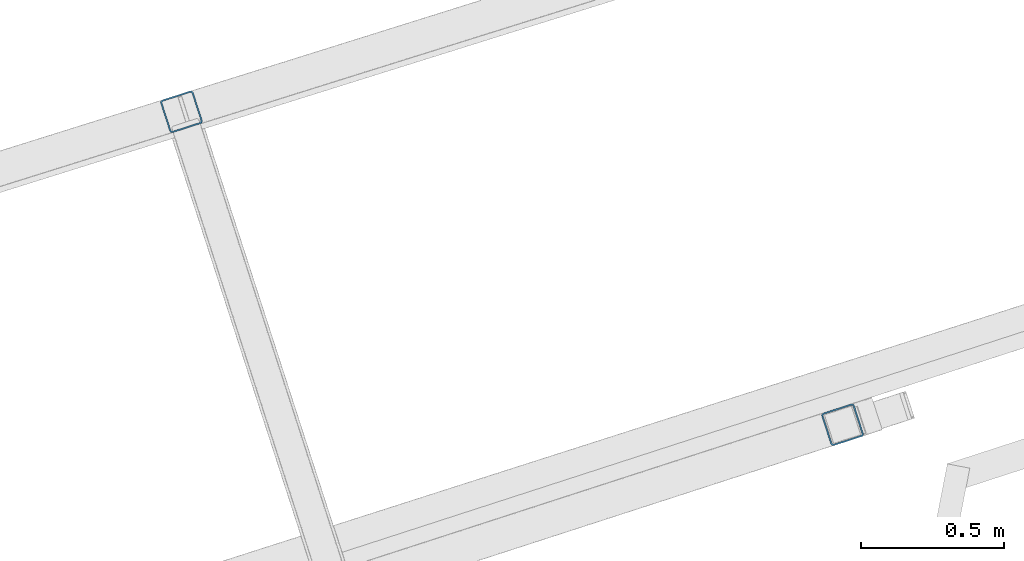
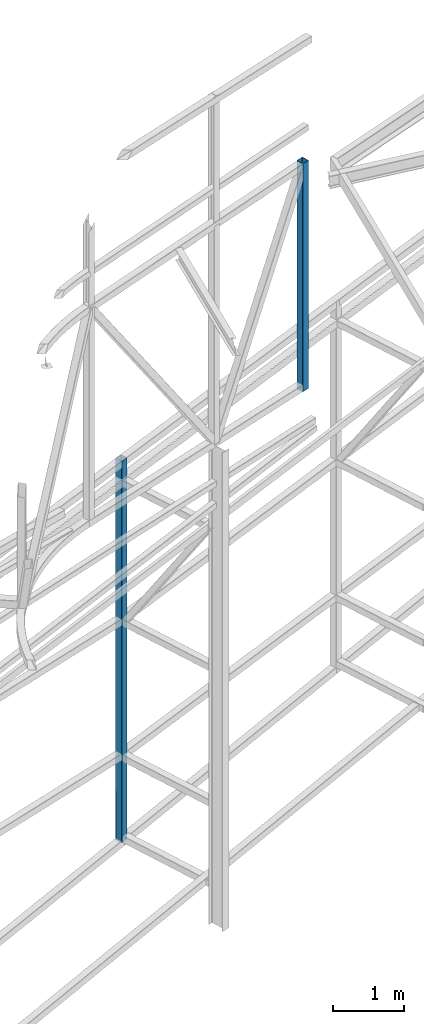
# One storey, part 84 of 215: 2 beams, 2 elements without a shape of their own.
"""IFC2X3 building model written with IfcOpenShell, lengths in millimetres."""

from ifc_helpers import new_model, si_unit, frame, origin_with_axes, origin_2d_with_axis, place, context, subcontext, project, spatial, hollow_rectangle, extrude, clip, halfspace, material, type_object, element, aggregate, save


model = new_model("IFC2X3")

# Units and contexts
model_context = context("Model", 3, precision=1e-05, world=origin_with_axes())
body_context = subcontext(model_context, "Body", "Model", "MODEL_VIEW")
ifc_project = project(units=[si_unit("LENGTHUNIT", "METRE", prefix="MILLI"), si_unit("AREAUNIT", "SQUARE_METRE"), si_unit("VOLUMEUNIT", "CUBIC_METRE"), si_unit("MASSUNIT", "GRAM", prefix="KILO"), si_unit("TIMEUNIT", "SECOND"), si_unit("PLANEANGLEUNIT", "RADIAN"), si_unit("SOLIDANGLEUNIT", "STERADIAN"), si_unit("THERMODYNAMICTEMPERATUREUNIT", "DEGREE_CELSIUS"), si_unit("LUMINOUSINTENSITYUNIT", "LUMEN")], contexts=[model_context])

# Site, building, storey
site_placement = place(None, origin_with_axes())
site = spatial("IfcSite", under=ifc_project, at=site_placement, CompositionType="ELEMENT")
building_placement = place(site_placement, origin_with_axes())
building = spatial("IfcBuilding", under=site, at=building_placement, Name="Undefined", CompositionType="ELEMENT")
storey_placement = place(building_placement, origin_with_axes())
storey = spatial("IfcBuildingStorey", under=building, at=storey_placement, Name="Undefined", CompositionType="ELEMENT", Elevation=0.0)

# Assembly, beam
assembly_1_placement = place(storey_placement, origin_with_axes())
assembly_1 = element("IfcElementAssembly", 1, at=assembly_1_placement, inside=storey, Name="Steel Assembly", AssemblyPlace="NOTDEFINED", PredefinedType="RIGID_FRAME")
ifc_material = material(Name="STEEL/S275JR")
beam_type = type_object("IfcBeamType", PredefinedType="NOTDEFINED")
beam_1_placement = place(assembly_1_placement, frame((47036.849762973, 61000.6606272937, 7164.53280482066), z_axis=(0.308275434998926, -0.951297143996671, -1.00000033853226e-09), x_axis=(0.0, 0.0, -1.0)))
beam_1 = element("IfcBeam", 2, at=beam_1_placement, type_object=beam_type, material=ifc_material, Name="MONTANT", context=body_context, shape_type="Clipping", body=[
    clip(extrude(hollow_rectangle(XDim=120.0, YDim=120.0, WallThickness=5.0, InnerFilletRadius=5.0, OuterFilletRadius=10.0, at=origin_2d_with_axis()), frame((6545.32728758946, 7.27595761418343e-12, 0.0), z_axis=(-1.0, 0.0, 0.0), x_axis=(-6.93889390390723e-18, -1.0, -3.46944695195361e-18)), (0.0, 0.0, 1.0), 6545.3), halfspace(frame((6521.02684267862, 98.8298096198778, -57.3770582198631), z_axis=(0.988585726357846, 0.15065294615068, 0.00139694582977652), x_axis=(1.00281522507307e-09, 0.00927220358092168, -0.999957012196401)), False)),
])
aggregate(assembly_1, [beam_1])

assembly_2_placement = place(storey_placement, origin_with_axes())
assembly_2 = element("IfcElementAssembly", 3, at=assembly_2_placement, inside=storey, Name="Steel Assembly", AssemblyPlace="NOTDEFINED", PredefinedType="RIGID_FRAME")
beam_2_placement = place(assembly_2_placement, frame((49346.4517888627, 59907.3755954603, 12123.3320193479), z_axis=(0.308275434998926, -0.951297143996671, -1.00000033853226e-09), x_axis=(0.0, 0.0, -1.0)))
beam_2 = element("IfcBeam", 4, at=beam_2_placement, type_object=beam_type, material=ifc_material, Name="LISSE", context=body_context, shape_type="SweptSolid", body=[
    extrude(hollow_rectangle(XDim=120.0, YDim=120.0, WallThickness=5.0, InnerFilletRadius=5.0, OuterFilletRadius=10.0, at=origin_2d_with_axis()), frame((3912.2043888745, 0.0, 0.0), z_axis=(-1.0, 0.0, 0.0), x_axis=(-6.93889390390723e-18, -1.0, -3.46944695195361e-18)), (0.0, 0.0, 1.0), 3912.2),
])
aggregate(assembly_2, [beam_2])

save(model, "model.ifc")
